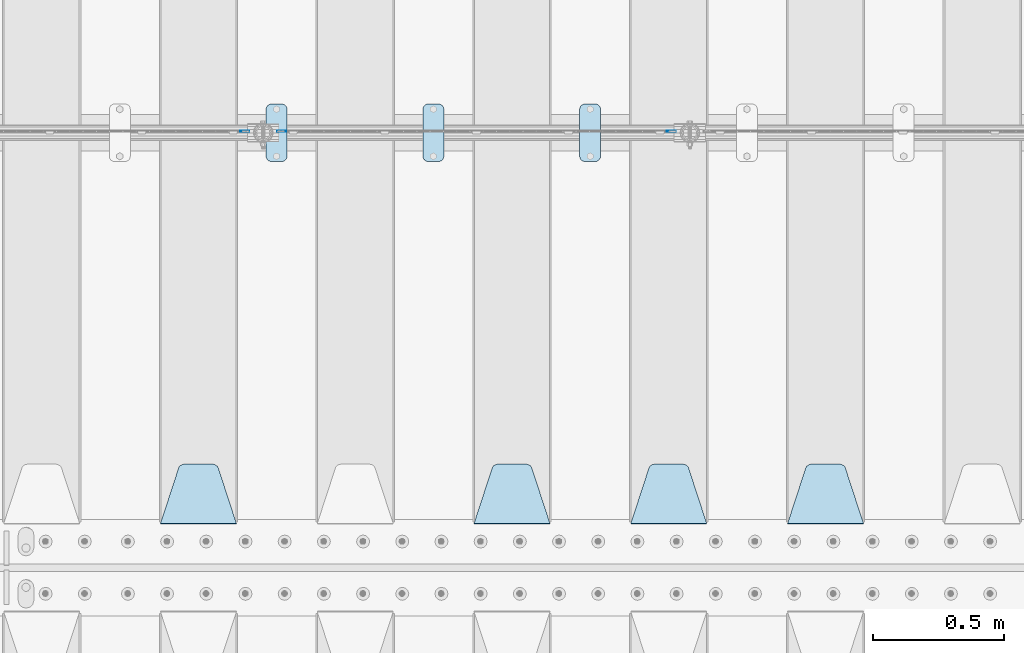
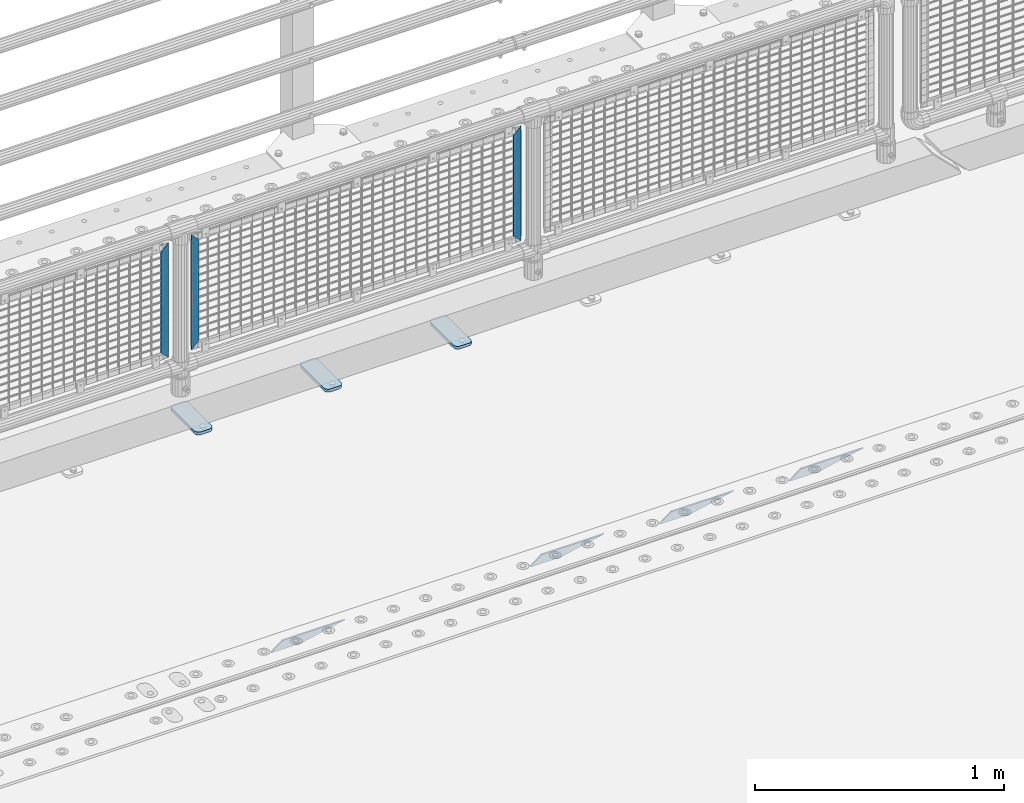
# One storey, part 222 of 242: 10 plates.
"""IFC2X3 building model written with IfcOpenShell, lengths in millimetres."""

from ifc_helpers import new_model, si_unit, frame, origin_with_axes, place, context, subcontext, project, spatial, faceted_brep, material, type_object, element, save


model = new_model("IFC2X3")

# Units and contexts
model_context = context("Model", 3, precision=1e-05, world=origin_with_axes())
body_context = subcontext(model_context, "Body", "Model", "MODEL_VIEW")
ifc_project = project(units=[si_unit("LENGTHUNIT", "METRE", prefix="MILLI"), si_unit("AREAUNIT", "SQUARE_METRE"), si_unit("VOLUMEUNIT", "CUBIC_METRE"), si_unit("MASSUNIT", "GRAM", prefix="KILO"), si_unit("TIMEUNIT", "SECOND"), si_unit("PLANEANGLEUNIT", "RADIAN"), si_unit("SOLIDANGLEUNIT", "STERADIAN"), si_unit("THERMODYNAMICTEMPERATUREUNIT", "DEGREE_CELSIUS"), si_unit("LUMINOUSINTENSITYUNIT", "LUMEN")], contexts=[model_context])

# Site, building, storey
site_placement = place(None, origin_with_axes())
site = spatial("IfcSite", under=ifc_project, at=site_placement, CompositionType="ELEMENT")
building_placement = place(site_placement, origin_with_axes())
building = spatial("IfcBuilding", under=site, at=building_placement, Name="Standard", CompositionType="ELEMENT")
storey_placement = place(building_placement, origin_with_axes())
storey = spatial("IfcBuildingStorey", under=building, at=storey_placement, Name="Undefined", CompositionType="ELEMENT", Elevation=0.0)

# Plates
ifc_material_1 = material(Name="Misc_Undefined")
plate_type_1 = type_object("IfcPlateType", PredefinedType="NOTDEFINED")
plate_1_placement = place(storey_placement, frame((-27043.490286459, -19329.5, 879.519963133601), z_axis=(-0.707008801899319, 0.0, -0.707204746899291), x_axis=(-0.707204746899296, 0.0, 0.707008801899313)))
element("IfcPlate", 1, at=plate_1_placement, inside=storey, type_object=plate_type_1, material=ifc_material_1, context=body_context, shape_type="Brep", body=[
    faceted_brep([(0.0, -1.50000000000364, 0.0), (-348.552185058597, -1.5, 348.655029296875), (-348.552185058597, 1.5, 348.655029296875), (-3.63797880709171e-12, 1.49999999999636, 0.0), (-348.544891357426, -1.5, 398.152496337891), (-348.544891357426, 1.5, 398.152496337891), (49.5043945312464, -1.5, 8.00355337560177e-11), (49.5043945312464, 1.5, 8.00355337560177e-11)], [[[0, 1, 2, 3]], [[1, 4, 5, 2]], [[4, 6, 7, 5]], [[6, 0, 3, 7]], [[5, 7, 3, 2]], [[6, 4, 1, 0]]]),
])
for number, where, z_axis, x_axis in (
    (2, (-25587.5003125164, -19329.5, 879.52), (0.707103624179499, 0.0, -0.707109938179501), (0.707109938179508, 0.0, 0.707103624179492)),
    (3, (-27220.5003125164, -19329.5, 879.52), (0.707103624179499, 0.0, -0.707109938179501), (0.707109938179508, 0.0, 0.707103624179492)),
):
    element("IfcPlate", number, at=place(storey_placement, frame(where, z_axis=z_axis, x_axis=x_axis)), inside=storey, type_object=plate_type_1, material=ifc_material_1, context=body_context, shape_type="Brep", body=[
        faceted_brep([(0.0, -1.50000000000364, 0.0), (-348.605163574222, -1.5, 348.602081298832), (-348.605163574222, 1.5, 348.602081298832), (-3.63797880709171e-12, 1.49999999999636, 0.0), (-348.605163574222, -1.5, 398.099334716801), (-348.605163574222, 1.5, 398.099334716801), (49.4976959228534, -1.5, -3.63797880709171e-12), (49.4976959228534, 1.5, -3.63797880709171e-12)], [[[0, 1, 2, 3]], [[1, 4, 5, 2]], [[4, 6, 7, 5]], [[6, 0, 3, 7]], [[5, 7, 3, 2]], [[6, 4, 1, 0]]]),
    ])
ifc_material_2 = material(Name="STEEL/S355J2")
plate_type_2 = type_object("IfcPlateType", PredefinedType="NOTDEFINED")
plate_2_placement = place(storey_placement, frame((-25921.0, -19225.5, 21.0199999999977), z_axis=(1.0, 0.0, 0.0), x_axis=(0.0, -1.0, 0.0)))
element("IfcPlate", 4, at=plate_2_placement, inside=storey, type_object=plate_type_2, material=ifc_material_2, context=body_context, shape_type="Brep", body=[
    faceted_brep([(0.0, -7.0, 20.0), (0.0, -7.0, 60.0), (0.0, 7.0, 60.0), (0.0, 7.0, 20.0), (0.384294391937146, -7.0, 63.9018064403208), (0.384294391937146, 7.0, 63.9018064403208), (1.52240934977453, -7.0, 67.6536686473009), (1.52240934977453, 7.0, 67.6536686473009), (3.37060775395003, -7.0, 71.1114046603907), (3.37060775395003, 7.0, 71.1114046603907), (5.8578643762703, -7.0, 74.1421356237297), (5.8578643762703, 7.0, 74.1421356237297), (8.88859533960931, -7.0, 76.62939224605), (8.88859533960931, 7.0, 76.62939224605), (12.3463313526991, -7.0, 78.4775906502255), (12.3463313526991, 7.0, 78.4775906502255), (16.0981935596792, -7.0, 79.6157056080629), (16.0981935596792, 7.0, 79.6157056080629), (20.0, -7.0, 80.0), (20.0, 7.0, 80.0), (200.0, -7.0, 80.0), (200.0, 7.0, 80.0), (203.901806440321, -7.0, 79.6157056080629), (203.901806440321, 7.0, 79.6157056080629), (207.653668647301, -7.0, 78.4775906502255), (207.653668647301, 7.0, 78.4775906502255), (211.111404660391, -7.0, 76.62939224605), (211.111404660391, 7.0, 76.62939224605), (214.14213562373, -7.0, 74.1421356237297), (214.14213562373, 7.0, 74.1421356237297), (216.62939224605, -7.0, 71.1114046603907), (216.62939224605, 7.0, 71.1114046603907), (218.477590650225, -7.0, 67.6536686473009), (218.477590650225, 7.0, 67.6536686473009), (219.615705608063, -7.0, 63.9018064403208), (219.615705608063, 7.0, 63.9018064403208), (220.0, -7.0, 60.0), (220.0, 7.0, 60.0), (220.0, -7.0, 20.0), (220.0, 7.0, 20.0), (219.615705608063, -7.0, 16.0981935596792), (219.615705608063, 7.0, 16.0981935596792), (218.477590650225, -7.0, 12.3463313526991), (218.477590650225, 7.0, 12.3463313526991), (216.62939224605, -7.0, 8.88859533960931), (216.62939224605, 7.0, 8.88859533960931), (214.14213562373, -7.0, 5.8578643762703), (214.14213562373, 7.0, 5.8578643762703), (211.111404660391, -7.0, 3.37060775395003), (211.111404660391, 7.0, 3.37060775395003), (207.653668647301, -7.0, 1.52240934977453), (207.653668647301, 7.0, 1.52240934977453), (203.901806440321, -7.0, 0.384294391937146), (203.901806440321, 7.0, 0.384294391937146), (200.0, -7.0, 0.0), (200.0, 7.0, 0.0), (20.0, -7.0, 0.0), (20.0, 7.0, 0.0), (16.0981935596792, -7.0, 0.384294391937146), (16.0981935596792, 7.0, 0.384294391937146), (12.3463313526991, -7.0, 1.52240934977453), (12.3463313526991, 7.0, 1.52240934977453), (8.88859533960931, -7.0, 3.37060775395003), (8.88859533960931, 7.0, 3.37060775395003), (5.8578643762703, -7.0, 5.8578643762703), (5.8578643762703, 7.0, 5.8578643762703), (3.37060775395003, -7.0, 8.88859533960931), (3.37060775395003, 7.0, 8.88859533960931), (1.52240934977453, -7.0, 12.3463313526991), (1.52240934977453, 7.0, 12.3463313526991), (0.384294391937146, -7.0, 16.0981935596792), (0.384294391937146, 7.0, 16.0981935596792)], [[[0, 1, 2, 3]], [[1, 4, 5, 2]], [[4, 6, 7, 5]], [[6, 8, 9, 7]], [[8, 10, 11, 9]], [[10, 12, 13, 11]], [[12, 14, 15, 13]], [[14, 16, 17, 15]], [[16, 18, 19, 17]], [[18, 20, 21, 19]], [[20, 22, 23, 21]], [[22, 24, 25, 23]], [[24, 26, 27, 25]], [[26, 28, 29, 27]], [[28, 30, 31, 29]], [[30, 32, 33, 31]], [[32, 34, 35, 33]], [[34, 36, 37, 35]], [[36, 38, 39, 37]], [[38, 40, 41, 39]], [[40, 42, 43, 41]], [[42, 44, 45, 43]], [[44, 46, 47, 45]], [[46, 48, 49, 47]], [[48, 50, 51, 49]], [[50, 52, 53, 51]], [[52, 54, 55, 53]], [[54, 56, 57, 55]], [[56, 58, 59, 57]], [[58, 60, 61, 59]], [[60, 62, 63, 61]], [[62, 64, 65, 63]], [[64, 66, 67, 65]], [[66, 68, 69, 67]], [[68, 70, 71, 69]], [[70, 0, 3, 71]], [[5, 7, 9, 11, 13, 15, 17, 19, 21, 23, 25, 27, 29, 31, 33, 35, 37, 39, 41, 43, 45, 47, 49, 51, 53, 55, 57, 59, 61, 63, 65, 67, 69, 71, 3, 2]], [[70, 68, 66, 64, 62, 60, 58, 56, 54, 52, 50, 48, 46, 44, 42, 40, 38, 36, 34, 32, 30, 28, 26, 24, 22, 20, 18, 16, 14, 12, 10, 8, 6, 4, 1, 0]]]),
])
plate_3_placement = place(storey_placement, frame((-26521.0, -19225.5, 21.0199999999977), z_axis=(1.0, 0.0, 0.0), x_axis=(0.0, -1.0, 0.0)))
element("IfcPlate", 5, at=plate_3_placement, inside=storey, type_object=plate_type_2, material=ifc_material_2, context=body_context, shape_type="Brep", body=[
    faceted_brep([(0.0, -7.0, 20.0), (0.0, -7.0, 60.0), (0.0, 7.0, 60.0), (0.0, 7.0, 20.0), (0.384294391937146, -7.0, 63.9018064403208), (0.384294391937146, 7.0, 63.9018064403208), (1.52240934977453, -7.0, 67.6536686473009), (1.52240934977453, 7.0, 67.6536686473009), (3.37060775395003, -7.0, 71.1114046603907), (3.37060775395003, 7.0, 71.1114046603907), (5.8578643762703, -7.0, 74.1421356237297), (5.8578643762703, 7.0, 74.1421356237297), (8.88859533960931, -7.0, 76.62939224605), (8.88859533960931, 7.0, 76.62939224605), (12.3463313526991, -7.0, 78.4775906502255), (12.3463313526991, 7.0, 78.4775906502255), (16.0981935596792, -7.0, 79.6157056080629), (16.0981935596792, 7.0, 79.6157056080629), (20.0, -7.0, 80.0), (20.0, 7.0, 80.0), (200.0, -7.0, 80.0), (200.0, 7.0, 80.0), (203.901806440321, -7.0, 79.6157056080629), (203.901806440321, 7.0, 79.6157056080629), (207.653668647301, -7.0, 78.4775906502255), (207.653668647301, 7.0, 78.4775906502255), (211.111404660391, -7.0, 76.62939224605), (211.111404660391, 7.0, 76.62939224605), (214.14213562373, -7.0, 74.1421356237297), (214.14213562373, 7.0, 74.1421356237297), (216.62939224605, -7.0, 71.1114046603907), (216.62939224605, 7.0, 71.1114046603907), (218.477590650225, -7.0, 67.6536686473009), (218.477590650225, 7.0, 67.6536686473009), (219.615705608063, -7.0, 63.9018064403208), (219.615705608063, 7.0, 63.9018064403208), (220.0, -7.0, 60.0), (220.0, 7.0, 60.0), (220.0, -7.0, 20.0), (220.0, 7.0, 20.0), (219.615705608063, -7.0, 16.0981935596792), (219.615705608063, 7.0, 16.0981935596792), (218.477590650225, -7.0, 12.3463313526991), (218.477590650225, 7.0, 12.3463313526991), (216.62939224605, -7.0, 8.88859533960931), (216.62939224605, 7.0, 8.88859533960931), (214.14213562373, -7.0, 5.8578643762703), (214.14213562373, 7.0, 5.8578643762703), (211.111404660391, -7.0, 3.37060775395003), (211.111404660391, 7.0, 3.37060775395003), (207.653668647301, -7.0, 1.52240934977453), (207.653668647301, 7.0, 1.52240934977453), (203.901806440321, -7.0, 0.384294391937146), (203.901806440321, 7.0, 0.384294391937146), (200.0, -7.0, 0.0), (200.0, 7.0, 0.0), (20.0, -7.0, 0.0), (20.0, 7.0, 0.0), (16.0981935596792, -7.0, 0.384294391937146), (16.0981935596792, 7.0, 0.384294391937146), (12.3463313526991, -7.0, 1.52240934977453), (12.3463313526991, 7.0, 1.52240934977453), (8.88859533960931, -7.0, 3.37060775395003), (8.88859533960931, 7.0, 3.37060775395003), (5.8578643762703, -7.0, 5.8578643762703), (5.8578643762703, 7.0, 5.8578643762703), (3.37060775395003, -7.0, 8.88859533960931), (3.37060775395003, 7.0, 8.88859533960931), (1.52240934977453, -7.0, 12.3463313526991), (1.52240934977453, 7.0, 12.3463313526991), (0.384294391937146, -7.0, 16.0981935596792), (0.384294391937146, 7.0, 16.0981935596792)], [[[0, 1, 2, 3]], [[1, 4, 5, 2]], [[4, 6, 7, 5]], [[6, 8, 9, 7]], [[8, 10, 11, 9]], [[10, 12, 13, 11]], [[12, 14, 15, 13]], [[14, 16, 17, 15]], [[16, 18, 19, 17]], [[18, 20, 21, 19]], [[20, 22, 23, 21]], [[22, 24, 25, 23]], [[24, 26, 27, 25]], [[26, 28, 29, 27]], [[28, 30, 31, 29]], [[30, 32, 33, 31]], [[32, 34, 35, 33]], [[34, 36, 37, 35]], [[36, 38, 39, 37]], [[38, 40, 41, 39]], [[40, 42, 43, 41]], [[42, 44, 45, 43]], [[44, 46, 47, 45]], [[46, 48, 49, 47]], [[48, 50, 51, 49]], [[50, 52, 53, 51]], [[52, 54, 55, 53]], [[54, 56, 57, 55]], [[56, 58, 59, 57]], [[58, 60, 61, 59]], [[60, 62, 63, 61]], [[62, 64, 65, 63]], [[64, 66, 67, 65]], [[66, 68, 69, 67]], [[68, 70, 71, 69]], [[70, 0, 3, 71]], [[5, 7, 9, 11, 13, 15, 17, 19, 21, 23, 25, 27, 29, 31, 33, 35, 37, 39, 41, 43, 45, 47, 49, 51, 53, 55, 57, 59, 61, 63, 65, 67, 69, 71, 3, 2]], [[70, 68, 66, 64, 62, 60, 58, 56, 54, 52, 50, 48, 46, 44, 42, 40, 38, 36, 34, 32, 30, 28, 26, 24, 22, 20, 18, 16, 14, 12, 10, 8, 6, 4, 1, 0]]]),
])
plate_4_placement = place(storey_placement, frame((-27121.0, -19225.5, 21.0199999999977), z_axis=(1.0, 0.0, 0.0), x_axis=(0.0, -1.0, 0.0)))
element("IfcPlate", 6, at=plate_4_placement, inside=storey, type_object=plate_type_2, material=ifc_material_2, context=body_context, shape_type="Brep", body=[
    faceted_brep([(0.0, -7.0, 20.0), (0.0, -7.0, 60.0), (0.0, 7.0, 60.0), (0.0, 7.0, 20.0), (0.384294391937146, -7.0, 63.9018064403208), (0.384294391937146, 7.0, 63.9018064403208), (1.52240934977453, -7.0, 67.6536686473009), (1.52240934977453, 7.0, 67.6536686473009), (3.37060775395003, -7.0, 71.1114046603907), (3.37060775395003, 7.0, 71.1114046603907), (5.8578643762703, -7.0, 74.1421356237297), (5.8578643762703, 7.0, 74.1421356237297), (8.88859533960931, -7.0, 76.62939224605), (8.88859533960931, 7.0, 76.62939224605), (12.3463313526991, -7.0, 78.4775906502255), (12.3463313526991, 7.0, 78.4775906502255), (16.0981935596792, -7.0, 79.6157056080629), (16.0981935596792, 7.0, 79.6157056080629), (20.0, -7.0, 80.0), (20.0, 7.0, 80.0), (200.0, -7.0, 80.0), (200.0, 7.0, 80.0), (203.901806440321, -7.0, 79.6157056080629), (203.901806440321, 7.0, 79.6157056080629), (207.653668647301, -7.0, 78.4775906502255), (207.653668647301, 7.0, 78.4775906502255), (211.111404660391, -7.0, 76.62939224605), (211.111404660391, 7.0, 76.62939224605), (214.14213562373, -7.0, 74.1421356237297), (214.14213562373, 7.0, 74.1421356237297), (216.62939224605, -7.0, 71.1114046603907), (216.62939224605, 7.0, 71.1114046603907), (218.477590650225, -7.0, 67.6536686473009), (218.477590650225, 7.0, 67.6536686473009), (219.615705608063, -7.0, 63.9018064403208), (219.615705608063, 7.0, 63.9018064403208), (220.0, -7.0, 60.0), (220.0, 7.0, 60.0), (220.0, -7.0, 20.0), (220.0, 7.0, 20.0), (219.615705608063, -7.0, 16.0981935596792), (219.615705608063, 7.0, 16.0981935596792), (218.477590650225, -7.0, 12.3463313526991), (218.477590650225, 7.0, 12.3463313526991), (216.62939224605, -7.0, 8.88859533960931), (216.62939224605, 7.0, 8.88859533960931), (214.14213562373, -7.0, 5.8578643762703), (214.14213562373, 7.0, 5.8578643762703), (211.111404660391, -7.0, 3.37060775395003), (211.111404660391, 7.0, 3.37060775395003), (207.653668647301, -7.0, 1.52240934977453), (207.653668647301, 7.0, 1.52240934977453), (203.901806440321, -7.0, 0.384294391937146), (203.901806440321, 7.0, 0.384294391937146), (200.0, -7.0, 0.0), (200.0, 7.0, 0.0), (20.0, -7.0, 0.0), (20.0, 7.0, 0.0), (16.0981935596792, -7.0, 0.384294391937146), (16.0981935596792, 7.0, 0.384294391937146), (12.3463313526991, -7.0, 1.52240934977453), (12.3463313526991, 7.0, 1.52240934977453), (8.88859533960931, -7.0, 3.37060775395003), (8.88859533960931, 7.0, 3.37060775395003), (5.8578643762703, -7.0, 5.8578643762703), (5.8578643762703, 7.0, 5.8578643762703), (3.37060775395003, -7.0, 8.88859533960931), (3.37060775395003, 7.0, 8.88859533960931), (1.52240934977453, -7.0, 12.3463313526991), (1.52240934977453, 7.0, 12.3463313526991), (0.384294391937146, -7.0, 16.0981935596792), (0.384294391937146, 7.0, 16.0981935596792)], [[[0, 1, 2, 3]], [[1, 4, 5, 2]], [[4, 6, 7, 5]], [[6, 8, 9, 7]], [[8, 10, 11, 9]], [[10, 12, 13, 11]], [[12, 14, 15, 13]], [[14, 16, 17, 15]], [[16, 18, 19, 17]], [[18, 20, 21, 19]], [[20, 22, 23, 21]], [[22, 24, 25, 23]], [[24, 26, 27, 25]], [[26, 28, 29, 27]], [[28, 30, 31, 29]], [[30, 32, 33, 31]], [[32, 34, 35, 33]], [[34, 36, 37, 35]], [[36, 38, 39, 37]], [[38, 40, 41, 39]], [[40, 42, 43, 41]], [[42, 44, 45, 43]], [[44, 46, 47, 45]], [[46, 48, 49, 47]], [[48, 50, 51, 49]], [[50, 52, 53, 51]], [[52, 54, 55, 53]], [[54, 56, 57, 55]], [[56, 58, 59, 57]], [[58, 60, 61, 59]], [[60, 62, 63, 61]], [[62, 64, 65, 63]], [[64, 66, 67, 65]], [[66, 68, 69, 67]], [[68, 70, 71, 69]], [[70, 0, 3, 71]], [[5, 7, 9, 11, 13, 15, 17, 19, 21, 23, 25, 27, 29, 31, 33, 35, 37, 39, 41, 43, 45, 47, 49, 51, 53, 55, 57, 59, 61, 63, 65, 67, 69, 71, 3, 2]], [[70, 68, 66, 64, 62, 60, 58, 56, 54, 52, 50, 48, 46, 44, 42, 40, 38, 36, 34, 32, 30, 28, 26, 24, 22, 20, 18, 16, 14, 12, 10, 8, 6, 4, 1, 0]]]),
])
ifc_material_3 = material(Name="STEEL/S355N")
plate_type_3 = type_object("IfcPlateType", PredefinedType="NOTDEFINED")
plate_5_placement = place(storey_placement, frame((-24835.0, -20831.767766953, -1.76776695296758), z_axis=(0.0, 0.707106781186547, -0.707106781186548), x_axis=(-1.0, 0.0, 0.0)))
element("IfcPlate", 7, at=plate_5_placement, inside=storey, type_object=plate_type_3, material=ifc_material_3, context=body_context, shape_type="Brep", body=[
    faceted_brep([(0.0, -2.5, 0.0), (69.345504679477, -2.50000000000182, 300.171731424829), (69.345504679477, 2.5, 300.171731424829), (0.0, 2.5, 0.0), (70.9274061199576, -2.5, 304.897442415398), (70.9274061199576, 2.5, 304.897442415398), (73.3818627772307, -2.5, 309.234538108525), (73.3818627772307, 2.50000000000182, 309.234538108529), (76.6187032999551, -2.5, 313.023683126101), (76.6187032999551, 2.50000000000182, 313.023683126103), (80.5190132704993, -2.5, 316.12567259537), (80.5190132704993, 2.5, 316.12567259537), (84.9395038596849, -2.5, 318.426546230474), (84.9395038596849, 2.50000000000182, 318.426546230476), (89.7177759439219, -2.49999999999818, 319.841774983273), (89.7177759439219, 2.50000000000182, 319.841774983273), (94.678286292652, -2.5, 320.319366455076), (94.678286292652, 2.5, 320.319366455076), (195.321713707348, -2.5, 320.319366455076), (195.321713707348, 2.5, 320.319366455076), (200.282224056078, -2.5, 319.841774983272), (200.282224056078, 2.50000000000182, 319.841774983273), (205.060496140315, -2.5, 318.426546230474), (205.060496140315, 2.49999999999818, 318.426546230474), (209.480986729501, -2.49999999999818, 316.12567259537), (209.480986729501, 2.5, 316.12567259537), (213.381296700045, -2.5, 313.023683126101), (213.381296700045, 2.49999999999818, 313.023683126101), (216.618137222769, -2.5, 309.234538108525), (216.618137222769, 2.5, 309.234538108523), (219.072593880042, -2.49999999999818, 304.897442415398), (219.072593880042, 2.50000000000182, 304.897442415398), (220.654495320523, -2.50000000000182, 300.171731424829), (220.654495320523, 2.5, 300.171731424829), (290.0, -2.5, 0.0), (290.0, 2.5, -1.81898940354586e-12)], [[[0, 1, 2, 3]], [[1, 4, 5, 2]], [[4, 6, 7, 5]], [[6, 8, 9, 7]], [[8, 10, 11, 9]], [[10, 12, 13, 11]], [[12, 14, 15, 13]], [[14, 16, 17, 15]], [[16, 18, 19, 17]], [[18, 20, 21, 19]], [[20, 22, 23, 21]], [[22, 24, 25, 23]], [[24, 26, 27, 25]], [[26, 28, 29, 27]], [[28, 30, 31, 29]], [[30, 32, 33, 31]], [[32, 34, 35, 33]], [[34, 0, 3, 35]], [[5, 7, 9, 11, 13, 15, 17, 19, 21, 23, 25, 27, 29, 31, 33, 35, 3, 2]], [[34, 32, 30, 28, 26, 24, 22, 20, 18, 16, 14, 12, 10, 8, 6, 4, 1, 0]]]),
])
plate_6_placement = place(storey_placement, frame((-25435.0, -20831.767766953, -1.76776695296758), z_axis=(0.0, 0.707106781186547, -0.707106781186548), x_axis=(-1.0, 0.0, 0.0)))
element("IfcPlate", 8, at=plate_6_placement, inside=storey, type_object=plate_type_3, material=ifc_material_3, context=body_context, shape_type="Brep", body=[
    faceted_brep([(0.0, -2.5, 0.0), (69.345504679477, -2.50000000000182, 300.171731424829), (69.345504679477, 2.5, 300.171731424829), (0.0, 2.5, 0.0), (70.9274061199576, -2.5, 304.897442415398), (70.9274061199576, 2.5, 304.897442415398), (73.3818627772307, -2.5, 309.234538108525), (73.3818627772307, 2.50000000000182, 309.234538108529), (76.6187032999551, -2.5, 313.023683126101), (76.6187032999551, 2.50000000000182, 313.023683126103), (80.5190132704993, -2.5, 316.12567259537), (80.5190132704993, 2.5, 316.12567259537), (84.9395038596849, -2.5, 318.426546230474), (84.9395038596849, 2.50000000000182, 318.426546230476), (89.7177759439219, -2.49999999999818, 319.841774983273), (89.7177759439219, 2.50000000000182, 319.841774983273), (94.678286292652, -2.5, 320.319366455076), (94.678286292652, 2.5, 320.319366455076), (195.321713707348, -2.5, 320.319366455076), (195.321713707348, 2.5, 320.319366455076), (200.282224056078, -2.5, 319.841774983272), (200.282224056078, 2.50000000000182, 319.841774983273), (205.060496140315, -2.5, 318.426546230474), (205.060496140315, 2.49999999999818, 318.426546230474), (209.480986729501, -2.49999999999818, 316.12567259537), (209.480986729501, 2.5, 316.12567259537), (213.381296700045, -2.5, 313.023683126101), (213.381296700045, 2.49999999999818, 313.023683126101), (216.618137222769, -2.5, 309.234538108525), (216.618137222769, 2.5, 309.234538108523), (219.072593880042, -2.49999999999818, 304.897442415398), (219.072593880042, 2.50000000000182, 304.897442415398), (220.654495320523, -2.50000000000182, 300.171731424829), (220.654495320523, 2.5, 300.171731424829), (290.0, -2.5, 0.0), (290.0, 2.5, -1.81898940354586e-12)], [[[0, 1, 2, 3]], [[1, 4, 5, 2]], [[4, 6, 7, 5]], [[6, 8, 9, 7]], [[8, 10, 11, 9]], [[10, 12, 13, 11]], [[12, 14, 15, 13]], [[14, 16, 17, 15]], [[16, 18, 19, 17]], [[18, 20, 21, 19]], [[20, 22, 23, 21]], [[22, 24, 25, 23]], [[24, 26, 27, 25]], [[26, 28, 29, 27]], [[28, 30, 31, 29]], [[30, 32, 33, 31]], [[32, 34, 35, 33]], [[34, 0, 3, 35]], [[5, 7, 9, 11, 13, 15, 17, 19, 21, 23, 25, 27, 29, 31, 33, 35, 3, 2]], [[34, 32, 30, 28, 26, 24, 22, 20, 18, 16, 14, 12, 10, 8, 6, 4, 1, 0]]]),
])
plate_7_placement = place(storey_placement, frame((-26035.0, -20831.767766953, -1.76776695296758), z_axis=(0.0, 0.707106781186547, -0.707106781186548), x_axis=(-1.0, 0.0, 0.0)))
element("IfcPlate", 9, at=plate_7_placement, inside=storey, type_object=plate_type_3, material=ifc_material_3, context=body_context, shape_type="Brep", body=[
    faceted_brep([(0.0, -2.5, 0.0), (69.345504679477, -2.50000000000182, 300.171731424829), (69.345504679477, 2.5, 300.171731424829), (0.0, 2.5, 0.0), (70.9274061199576, -2.5, 304.897442415398), (70.9274061199576, 2.5, 304.897442415398), (73.3818627772307, -2.5, 309.234538108525), (73.3818627772307, 2.50000000000182, 309.234538108529), (76.6187032999551, -2.5, 313.023683126101), (76.6187032999551, 2.50000000000182, 313.023683126103), (80.5190132704993, -2.5, 316.12567259537), (80.5190132704993, 2.5, 316.12567259537), (84.9395038596849, -2.5, 318.426546230474), (84.9395038596849, 2.50000000000182, 318.426546230476), (89.7177759439219, -2.49999999999818, 319.841774983273), (89.7177759439219, 2.50000000000182, 319.841774983273), (94.678286292652, -2.5, 320.319366455076), (94.678286292652, 2.5, 320.319366455076), (195.321713707348, -2.5, 320.319366455076), (195.321713707348, 2.5, 320.319366455076), (200.282224056078, -2.5, 319.841774983272), (200.282224056078, 2.50000000000182, 319.841774983273), (205.060496140315, -2.5, 318.426546230474), (205.060496140315, 2.49999999999818, 318.426546230474), (209.480986729501, -2.49999999999818, 316.12567259537), (209.480986729501, 2.5, 316.12567259537), (213.381296700045, -2.5, 313.023683126101), (213.381296700045, 2.49999999999818, 313.023683126101), (216.618137222769, -2.5, 309.234538108525), (216.618137222769, 2.5, 309.234538108523), (219.072593880042, -2.49999999999818, 304.897442415398), (219.072593880042, 2.50000000000182, 304.897442415398), (220.654495320523, -2.50000000000182, 300.171731424829), (220.654495320523, 2.5, 300.171731424829), (290.0, -2.5, 0.0), (290.0, 2.5, -1.81898940354586e-12)], [[[0, 1, 2, 3]], [[1, 4, 5, 2]], [[4, 6, 7, 5]], [[6, 8, 9, 7]], [[8, 10, 11, 9]], [[10, 12, 13, 11]], [[12, 14, 15, 13]], [[14, 16, 17, 15]], [[16, 18, 19, 17]], [[18, 20, 21, 19]], [[20, 22, 23, 21]], [[22, 24, 25, 23]], [[24, 26, 27, 25]], [[26, 28, 29, 27]], [[28, 30, 31, 29]], [[30, 32, 33, 31]], [[32, 34, 35, 33]], [[34, 0, 3, 35]], [[5, 7, 9, 11, 13, 15, 17, 19, 21, 23, 25, 27, 29, 31, 33, 35, 3, 2]], [[34, 32, 30, 28, 26, 24, 22, 20, 18, 16, 14, 12, 10, 8, 6, 4, 1, 0]]]),
])
plate_8_placement = place(storey_placement, frame((-27235.0, -20831.767766953, -1.76776695296758), z_axis=(0.0, 0.707106781186547, -0.707106781186548), x_axis=(-1.0, 0.0, 0.0)))
element("IfcPlate", 10, at=plate_8_placement, inside=storey, type_object=plate_type_3, material=ifc_material_3, context=body_context, shape_type="Brep", body=[
    faceted_brep([(0.0, -2.5, 0.0), (69.345504679477, -2.50000000000182, 300.171731424829), (69.345504679477, 2.5, 300.171731424829), (0.0, 2.5, 0.0), (70.9274061199576, -2.5, 304.897442415398), (70.9274061199576, 2.5, 304.897442415398), (73.3818627772307, -2.5, 309.234538108525), (73.3818627772307, 2.50000000000182, 309.234538108529), (76.6187032999551, -2.5, 313.023683126101), (76.6187032999551, 2.50000000000182, 313.023683126103), (80.5190132704993, -2.5, 316.12567259537), (80.5190132704993, 2.5, 316.12567259537), (84.9395038596849, -2.5, 318.426546230474), (84.9395038596849, 2.50000000000182, 318.426546230476), (89.7177759439219, -2.49999999999818, 319.841774983273), (89.7177759439219, 2.50000000000182, 319.841774983273), (94.678286292652, -2.5, 320.319366455076), (94.678286292652, 2.5, 320.319366455076), (195.321713707348, -2.5, 320.319366455076), (195.321713707348, 2.5, 320.319366455076), (200.282224056078, -2.5, 319.841774983272), (200.282224056078, 2.50000000000182, 319.841774983273), (205.060496140315, -2.5, 318.426546230474), (205.060496140315, 2.49999999999818, 318.426546230474), (209.480986729501, -2.49999999999818, 316.12567259537), (209.480986729501, 2.5, 316.12567259537), (213.381296700045, -2.5, 313.023683126101), (213.381296700045, 2.49999999999818, 313.023683126101), (216.618137222769, -2.5, 309.234538108525), (216.618137222769, 2.5, 309.234538108523), (219.072593880042, -2.49999999999818, 304.897442415398), (219.072593880042, 2.50000000000182, 304.897442415398), (220.654495320523, -2.50000000000182, 300.171731424829), (220.654495320523, 2.5, 300.171731424829), (290.0, -2.5, 0.0), (290.0, 2.5, -1.81898940354586e-12)], [[[0, 1, 2, 3]], [[1, 4, 5, 2]], [[4, 6, 7, 5]], [[6, 8, 9, 7]], [[8, 10, 11, 9]], [[10, 12, 13, 11]], [[12, 14, 15, 13]], [[14, 16, 17, 15]], [[16, 18, 19, 17]], [[18, 20, 21, 19]], [[20, 22, 23, 21]], [[22, 24, 25, 23]], [[24, 26, 27, 25]], [[26, 28, 29, 27]], [[28, 30, 31, 29]], [[30, 32, 33, 31]], [[32, 34, 35, 33]], [[34, 0, 3, 35]], [[5, 7, 9, 11, 13, 15, 17, 19, 21, 23, 25, 27, 29, 31, 33, 35, 3, 2]], [[34, 32, 30, 28, 26, 24, 22, 20, 18, 16, 14, 12, 10, 8, 6, 4, 1, 0]]]),
])

save(model, "model.ifc")
